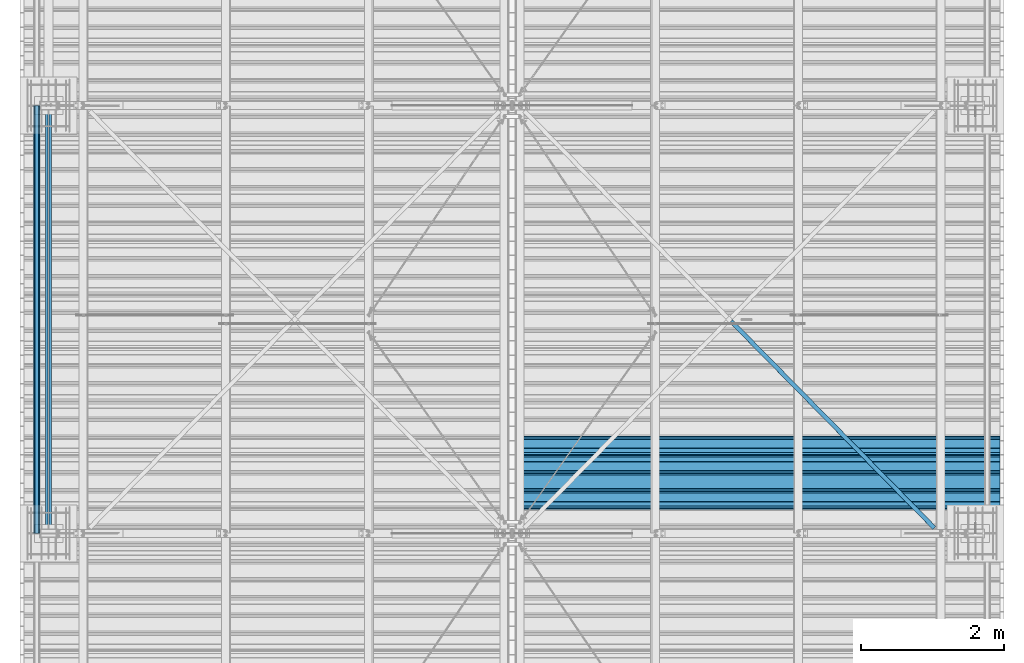
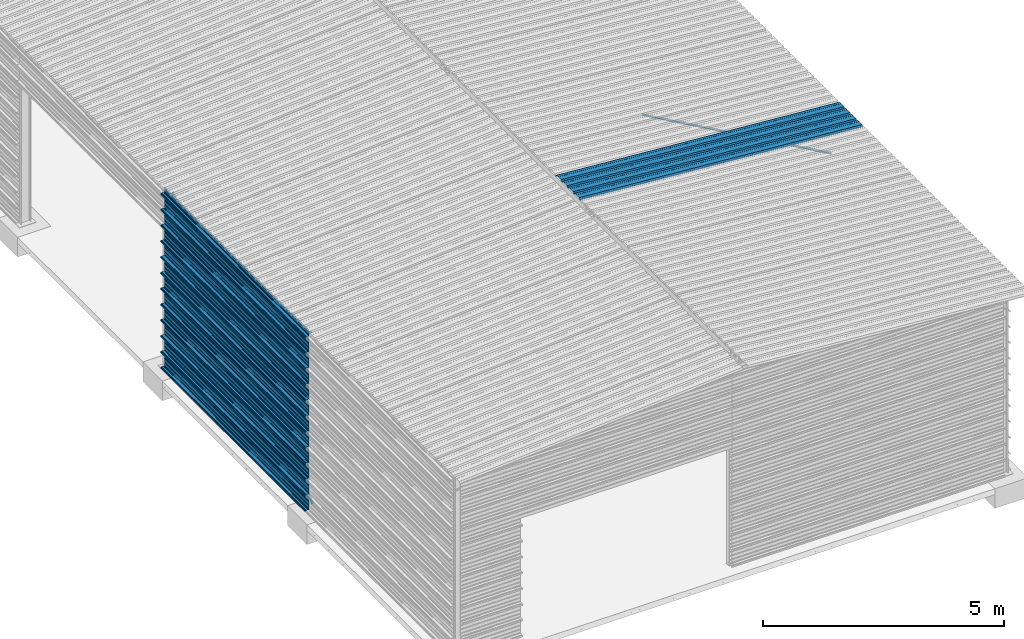
# One storey, part 10 of 70: 14 beams, 2 members, 16 elements without a shape of their own.
"""IFC2X3 building model written with IfcOpenShell, lengths in millimetres."""

import ifcopenshell
import ifcopenshell.guid

model = None  # the IFC model being written
_history = None  # IfcOwnerHistory: only IFC2X3 demands one
_inside = {}  # id of a spatial element -> (the spatial element, [elements in it])
_under = {}  # id of a project, library or spatial element -> (it, [spatial elements below it])
_declared = {}  # id of a project -> (the project, [libraries it declares])
_typed = {}  # id of a type object -> (the type object, [elements of that type])
_made_of = {}  # id of a material, layer set ... -> (it, [elements and type objects made of it])


def new_model(schema):
    """Start an empty IFC model of exactly this schema.

    Asked for "IFC4X3", IfcOpenShell would pick the latest addendum, in which some entities
    have other attributes; the version numbers below select the first issue.
    IFC2X3 requires an IfcOwnerHistory on every rooted entity: one is made here for all.
    """
    global model, _history
    if schema == "IFC4X3":
        model = ifcopenshell.file(schema_version=(4, 3, 0, 0))
    else:
        model = ifcopenshell.file(schema=schema)
    _inside.clear()
    _under.clear()
    _declared.clear()
    _typed.clear()
    _made_of.clear()
    _history = None
    if model.schema == "IFC2X3":
        org = make("IfcOrganization", Name="unknown")
        user = make(
            "IfcPersonAndOrganization",
            ThePerson=make("IfcPerson", FamilyName="unknown"),
            TheOrganization=org,
        )
        app = make(
            "IfcApplication",
            ApplicationDeveloper=org,
            Version="unknown",
            ApplicationFullName="unknown",
            ApplicationIdentifier="unknown",
        )
        _history = make(
            "IfcOwnerHistory",
            OwningUser=user,
            OwningApplication=app,
            ChangeAction="ADDED",
            CreationDate=0,
        )
    return model


def make(cls, **values):
    """One entity of the class cls with the attributes given. An attribute that is None is left unset."""
    return model.create_entity(
        cls, **{name: value for name, value in values.items() if value is not None}
    )


def rooted(cls, **values):
    """An entity with a GlobalId (a new one), such as an element, a storey or a relation."""
    return make(cls, GlobalId=ifcopenshell.guid.new(), OwnerHistory=_history, **values)


def si_unit(unit_type, name, prefix=None):
    """IfcSIUnit, for example si_unit("LENGTHUNIT", "METRE", prefix="MILLI")."""
    return make("IfcSIUnit", UnitType=unit_type, Prefix=prefix, Name=name)


def assignment(units):
    """IfcUnitAssignment: the units of a project."""
    return None if units is None else make("IfcUnitAssignment", Units=units)


def point(xyz):
    """IfcCartesianPoint."""
    return None if xyz is None else make("IfcCartesianPoint", Coordinates=xyz)


def direction(xyz):
    """IfcDirection."""
    return None if xyz is None else make("IfcDirection", DirectionRatios=xyz)


def frame(location, z_axis=None, x_axis=None):
    """IfcAxis2Placement3D, a coordinate frame: its origin and axes. An axis left out is left unset."""
    return make(
        "IfcAxis2Placement3D",
        Location=point(location),
        Axis=direction(z_axis),
        RefDirection=direction(x_axis),
    )


def frame_2d(location, x_axis=None):
    """IfcAxis2Placement2D, a coordinate frame in the plane: its origin and x axis."""
    return make(
        "IfcAxis2Placement2D", Location=point(location), RefDirection=direction(x_axis)
    )


def origin_with_axes():
    """The frame at (0, 0, 0) with the z axis (0, 0, 1) and the x axis (1, 0, 0) written out."""
    return frame((0.0, 0.0, 0.0), z_axis=(0.0, 0.0, 1.0), x_axis=(1.0, 0.0, 0.0))


def origin_2d_with_axis():
    """The frame at (0, 0) in the plane with the x axis (1, 0) written out."""
    return frame_2d((0.0, 0.0), x_axis=(1.0, 0.0))


def place(relative_to, where):
    """IfcLocalPlacement: puts the frame where relative to a parent placement (None: the world)."""
    return make(
        "IfcLocalPlacement", PlacementRelTo=relative_to, RelativePlacement=where
    )


def context(
    kind, dimensions, precision=None, world=None, true_north=None, identifier=None
):
    """IfcGeometricRepresentationContext, for example the 3D "Model" context."""
    return make(
        "IfcGeometricRepresentationContext",
        ContextIdentifier=identifier,
        ContextType=kind,
        CoordinateSpaceDimension=dimensions,
        Precision=precision,
        WorldCoordinateSystem=world,
        TrueNorth=true_north,
    )


def subcontext(parent, identifier, kind, view, scale=None):
    """IfcGeometricRepresentationSubContext, for example "Body" below "Model"."""
    return make(
        "IfcGeometricRepresentationSubContext",
        ContextIdentifier=identifier,
        ContextType=kind,
        ParentContext=parent,
        TargetScale=scale,
        TargetView=view,
    )


def project(units=None, contexts=None):
    """IfcProject with its units and contexts."""
    return rooted(
        "IfcProject",
        Name="project",
        RepresentationContexts=contexts,
        UnitsInContext=assignment(units),
    )


def spatial(cls, under=None, at=None, **own):
    """A site, building, storey or space (cls), placed at a placement, below another one or the project."""
    s = rooted(cls, ObjectPlacement=at, **own)
    if under is not None:
        _under.setdefault(under.id(), (under, []))[1].append(s)
    return s


def polyline(points):
    """IfcPolyline through the points."""
    return make("IfcPolyline", Points=[point(p) for p in points])


def profile(cls, at=None, kind="AREA", **sizes):
    """A parametric profile (cls). Its sizes go by their IFC names, for example OverallWidth=200.0."""
    return make(cls, ProfileType=kind, Position=at, **sizes)


def l_section(**sizes):
    """IfcLShapeProfileDef."""
    return profile("IfcLShapeProfileDef", **sizes)


def outline(outer, holes=None, kind="AREA"):
    """IfcArbitraryClosedProfileDef: a profile drawn as a closed curve; with holes, ...WithVoids."""
    if holes is None:
        return make("IfcArbitraryClosedProfileDef", ProfileType=kind, OuterCurve=outer)
    return make(
        "IfcArbitraryProfileDefWithVoids",
        ProfileType=kind,
        OuterCurve=outer,
        InnerCurves=holes,
    )


def extrude(swept, where, along, depth):
    """IfcExtrudedAreaSolid: the profile swept, set in the frame where, extruded along a direction by depth."""
    return make(
        "IfcExtrudedAreaSolid",
        SweptArea=swept,
        Position=where,
        ExtrudedDirection=direction(along),
        Depth=depth,
    )


def clip(a, b, op="DIFFERENCE"):
    """IfcBooleanClippingResult: the solid a cut by the half space b."""
    return make(
        "IfcBooleanClippingResult", Operator=op, FirstOperand=a, SecondOperand=b
    )


def halfspace(plane, agree):
    """IfcHalfSpaceSolid: all space on one side of the plane z = 0 of the frame plane."""
    return make(
        "IfcHalfSpaceSolid",
        BaseSurface=make("IfcPlane", Position=plane),
        AgreementFlag=agree,
    )


def shape(context_of_items, identifier, shape_type, items):
    """IfcShapeRepresentation: the items that make up one representation, for example the "Body"."""
    return make(
        "IfcShapeRepresentation",
        ContextOfItems=context_of_items,
        RepresentationIdentifier=identifier,
        RepresentationType=shape_type,
        Items=items,
    )


def material(Name=None, Category=None):
    """IfcMaterial."""
    return make("IfcMaterial", Name=Name, Category=Category)


def made_of(thing, what):
    """Note that an element or type object is made of a material, layer set ...; save() writes the relation."""
    if what is not None:
        _made_of.setdefault(what.id(), (what, []))[1].append(thing)
    return thing


def type_object(cls, material=None, **own):
    """A type object (cls), such as IfcWallType, which elements share."""
    return made_of(rooted(cls, **own), material)


def element(
    cls,
    number,
    at=None,
    inside=None,
    cuts=None,
    type_object=None,
    material=None,
    context=None,
    identifier="Body",
    shape_type=None,
    held_by="IfcProductDefinitionShape",
    body=None,
    shapes=None,
    **own,
):
    """One element of the class cls, such as IfcWall. Its Tag is "e" and its number.

    at: its placement. inside: the storey or other place that contains it. cuts: it is an
    opening in that element (IfcRelVoidsElement). A single representation is given by context,
    identifier, shape_type and body (its items); several are given by shapes. held_by: the class
    of the entity that holds the representations. save() writes the other relations.
    """
    e = rooted(cls, Tag="e%d" % number, ObjectPlacement=at, **own)
    if body is not None:
        shapes = [shape(context, identifier, shape_type, body)]
    if shapes is not None:
        e.Representation = make(held_by, Representations=shapes)
    if inside is not None:
        _inside.setdefault(inside.id(), (inside, []))[1].append(e)
    if cuts is not None:
        rooted(
            "IfcRelVoidsElement", RelatingBuildingElement=cuts, RelatedOpeningElement=e
        )
    if type_object is not None:
        _typed.setdefault(type_object.id(), (type_object, []))[1].append(e)
    return made_of(e, material)


def aggregate(whole, parts):
    """IfcRelAggregates: a whole, such as a stair, and the parts it consists of."""
    return rooted("IfcRelAggregates", RelatingObject=whole, RelatedObjects=parts)


def save(model, path):
    """Write the relations noted so far, then the file.

    IfcRelAggregates (storeys below a building ...), IfcRelContainedInSpatialStructure (elements
    in a storey), IfcRelDefinesByType, IfcRelAssociatesMaterial and IfcRelDeclares: one each for
    every whole, place, type object, material and project.
    """
    for whole, parts in _under.values():
        aggregate(whole, parts)
    for where, things in _inside.values():
        rooted(
            "IfcRelContainedInSpatialStructure",
            RelatedElements=things,
            RelatingStructure=where,
        )
    for kind, things in _typed.values():
        rooted("IfcRelDefinesByType", RelatedObjects=things, RelatingType=kind)
    for what, things in _made_of.values():
        rooted("IfcRelAssociatesMaterial", RelatedObjects=things, RelatingMaterial=what)
    for by, libraries in _declared.values():
        rooted("IfcRelDeclares", RelatingContext=by, RelatedDefinitions=libraries)
    model.write(path)


model = new_model("IFC2X3")

# Units and contexts
model_context = context("Model", 3, precision=1e-05, world=origin_with_axes())
body_context = subcontext(model_context, "Body", "Model", "MODEL_VIEW")
ifc_project = project(units=[si_unit("LENGTHUNIT", "METRE", prefix="MILLI"), si_unit("AREAUNIT", "SQUARE_METRE"), si_unit("VOLUMEUNIT", "CUBIC_METRE"), si_unit("MASSUNIT", "GRAM", prefix="KILO"), si_unit("TIMEUNIT", "SECOND"), si_unit("PLANEANGLEUNIT", "RADIAN"), si_unit("SOLIDANGLEUNIT", "STERADIAN"), si_unit("THERMODYNAMICTEMPERATUREUNIT", "DEGREE_CELSIUS"), si_unit("LUMINOUSINTENSITYUNIT", "LUMEN")], contexts=[model_context])

# Site, building, storey
site_placement = place(None, origin_with_axes())
site = spatial("IfcSite", under=ifc_project, at=site_placement, CompositionType="ELEMENT")
building_placement = place(site_placement, origin_with_axes())
building = spatial("IfcBuilding", under=site, at=building_placement, Name="Undefined", CompositionType="ELEMENT")
storey_placement = place(building_placement, origin_with_axes())
storey = spatial("IfcBuildingStorey", under=building, at=storey_placement, Name="Undefined", CompositionType="ELEMENT", Elevation=0.0)

# Assembly, member
assembly_1_placement = place(storey_placement, origin_with_axes())
assembly_1 = element("IfcElementAssembly", 1, at=assembly_1_placement, inside=storey, Name="Steel Assembly", AssemblyPlace="NOTDEFINED", PredefinedType="RIGID_FRAME")
ifc_material = material(Name="STEEL/S235JR")
member_type = type_object("IfcMemberType", PredefinedType="NOTDEFINED")
member_1_placement = place(assembly_1_placement, frame((-23.999999998379, 6091.79999354738, 4437.40000481649), z_axis=(0.0, -0.6, -0.8), x_axis=(0.0, 0.8, -0.6)))
member_1 = element("IfcMember", 2, at=member_1_placement, type_object=member_type, material=ifc_material, Name="POUTRE", context=body_context, shape_type="SweptSolid", body=[
    extrude(l_section(Depth=40.0, Width=40.0, Thickness=4.0, FilletRadius=6.0, EdgeRadius=3.0, at=origin_2d_with_axis()), frame((7267.75482272153, 0.0, 0.0), z_axis=(-1.0, 0.0, 0.0), x_axis=(0.0, -1.0, 0.0)), (0.0, 0.0, 1.0), 7267.75),
])
aggregate(assembly_1, [member_1])

assembly_2_placement = place(storey_placement, origin_with_axes())
assembly_2 = element("IfcElementAssembly", 3, at=assembly_2_placement, inside=storey, Name="Steel Assembly", AssemblyPlace="NOTDEFINED", PredefinedType="RIGID_FRAME")
member_2_placement = place(assembly_2_placement, frame((24.0000000026739, 6093.99614827963, 76.7471111867323), z_axis=(1.0, 0.0, 0.0), x_axis=(0.0, 0.8, 0.6)))
member_2 = element("IfcMember", 4, at=member_2_placement, type_object=member_type, material=ifc_material, Name="POUTRE", context=body_context, shape_type="SweptSolid", body=[
    extrude(l_section(Depth=40.0, Width=40.0, Thickness=4.0, FilletRadius=6.0, EdgeRadius=3.0, at=origin_2d_with_axis()), frame((7267.75482272153, 0.0, 0.0), z_axis=(-1.0, 0.0, 0.0), x_axis=(0.0, -1.0, 0.0)), (0.0, 0.0, 1.0), 7267.75),
])
aggregate(assembly_2, [member_2])

# Assembly, beam
assembly_3_placement = place(storey_placement, origin_with_axes())
assembly_3 = element("IfcElementAssembly", 5, at=assembly_3_placement, inside=storey, Name="Steel Assembly", AssemblyPlace="NOTDEFINED", PredefinedType="RIGID_FRAME")
beam_type_1 = type_object("IfcBeamType", Name="4.40", PredefinedType="NOTDEFINED")
beam_1_placement = place(assembly_3_placement, frame((6563.60751131961, 6850.00000000015, 5336.31760454369), z_axis=(-0.0766964990376782, 0.0, -0.997054485489817), x_axis=(0.997054485489817, 0.0, -0.0766964990376783)))
beam_1 = element("IfcBeam", 6, at=beam_1_placement, type_object=beam_type_1, material=ifc_material, ObjectType="4.40", context=body_context, shape_type="SweptSolid", body=[
    extrude(outline(polyline([(509.415161132813, 19.5000000011705), (490.584838867188, 19.5000000011705), (468.084838867188, -20.4999999988113), (406.585784912109, -20.4999999988113), (404.585784912109, -18.4999999988122), (345.414215087891, -18.4999999988122), (343.414215087891, -20.4999999988113), (281.915161132813, -20.4999999988113), (259.415161132813, 19.5000000011705), (240.584854125977, 19.5000000011705), (218.084854125977, -20.4999999988113), (156.585784912109, -20.4999999988113), (154.585784912109, -18.4999999988122), (95.4142150878906, -18.4999999988122), (93.4142150878906, -20.4999999988113), (31.9151515960693, -20.4999999988113), (9.41515254974365, 19.5000000011705), (-9.41515254974365, 19.5000000011705), (-31.9151515960693, -20.4999999988113), (-93.4142150878906, -20.4999999988113), (-95.4142150878906, -18.4999999988122), (-154.585784912109, -18.4999999988122), (-156.585784912109, -20.4999999988113), (-218.084854125977, -20.4999999988113), (-240.584854125977, 19.5000000011705), (-259.415161132813, 19.5000000011705), (-281.915161132813, -20.4999999988113), (-343.414215087891, -20.4999999988113), (-345.414215087891, -18.4999999988122), (-404.585784912109, -18.4999999988122), (-406.585784912109, -20.4999999988113), (-468.084838867188, -20.4999999988113), (-490.584838867188, 19.5000000011705), (-509.415161132813, 19.5000000011705), (-516.482360839844, 6.9361057293263), (-517.353942871094, 7.42636680720625), (-510.0, 20.5000000011705), (-490.0, 20.5000000011705), (-467.5, -19.4999999988122), (-407.0, -19.4999999988122), (-405.0, -17.4999999988131), (-345.0, -17.4999999988131), (-343.0, -19.4999999988122), (-282.5, -19.4999999988122), (-260.0, 20.5000000011705), (-240.0, 20.5000000011705), (-217.5, -19.4999999988122), (-157.0, -19.4999999988122), (-155.0, -17.4999999988131), (-95.0, -17.4999999988131), (-93.0, -19.4999999988122), (-32.5, -19.4999999988122), (-10.0, 20.5000000011705), (10.0, 20.5000000011705), (32.5, -19.4999999988122), (93.0, -19.4999999988122), (95.0, -17.4999999988131), (155.0, -17.4999999988131), (157.0, -19.4999999988122), (217.5, -19.4999999988122), (240.0, 20.5000000011705), (260.0, 20.5000000011705), (282.5, -19.4999999988122), (343.0, -19.4999999988122), (345.0, -17.4999999988131), (405.0, -17.4999999988131), (407.0, -19.4999999988122), (467.5, -19.4999999988122), (490.0, 20.5000000011705), (510.0, 20.5000000011705), (517.353942871094, 7.42636680720625), (516.482360839844, 6.9361057293263), (509.415161132813, 19.5000000011705)])), frame((6799.99999999733, 2.8421709430404e-14, 0.0), z_axis=(-1.0, 0.0, 0.0), x_axis=(0.0, -1.0, 0.0)), (0.0, 0.0, 1.0), 6800.0),
])
aggregate(assembly_3, [beam_1])

assembly_4_placement = place(storey_placement, origin_with_axes())
assembly_4 = element("IfcElementAssembly", 7, at=assembly_4_placement, inside=storey, Name="Steel Assembly", AssemblyPlace="NOTDEFINED", PredefinedType="RIGID_FRAME")
beam_type_2 = type_object("IfcBeamType", Name="400", PredefinedType="NOTDEFINED")
beam_2_placement = place(assembly_4_placement, frame((-165.499999998334, 6000.0, 4618.17396601053), z_axis=(-1.0, 0.0, 0.0), x_axis=(0.0, 1.0, 0.0)))
beam_2 = element("IfcBeam", 8, at=beam_2_placement, type_object=beam_type_2, material=ifc_material, ObjectType="400", context=body_context, shape_type="Clipping", body=[
    clip(extrude(outline(polyline([(218.25, -24.994083404541), (214.25, -31.8999996185303), (214.25, -45.5), (199.75, -45.5), (194.25, -42.5), (188.75, -45.5), (124.25, -45.5), (114.25, -41.5), (104.25, -45.5), (24.25, -45.5), (14.25, -41.5), (4.25, -45.5), (-75.75, -45.5), (-85.75, -41.5), (-95.75, -45.5), (-160.25, -45.5), (-165.75, -42.5), (-171.25, -45.5), (-185.75, -45.5), (-185.75, -30.711540222168), (-181.75, -23.8111782073975), (-181.75, 23.311637878418), (-185.75, 30.2119998931885), (-185.75, 44.5), (-217.25, 44.5), (-217.25, 34.7999992370605), (-218.25, 34.7999992370605), (-218.25, 45.5), (-184.75, 45.5), (-184.75, 30.480884552002), (-180.75, 23.5805225372314), (-180.75, -24.0800628662109), (-184.75, -30.9804248809814), (-184.75, -44.5), (-171.504989624023, -44.5), (-165.75, -41.360912322998), (-159.995010375977, -44.5), (-95.9425811767578, -44.5), (-85.75, -40.422966003418), (-75.5574188232422, -44.5), (4.05741739273071, -44.5), (14.25, -40.422966003418), (24.4425830841064, -44.5), (104.057418823242, -44.5), (114.25, -40.422966003418), (124.442581176758, -44.5), (188.495010375977, -44.5), (194.25, -41.360912322998), (200.004989624023, -44.5), (213.25, -44.5), (213.25, -31.6313018798828), (217.25, -24.7253856658936), (217.25, 21.7253856658936), (213.25, 28.6313018798828), (213.25, 42.0), (187.25, 42.0), (187.25, 32.5499992370605), (186.25, 32.5499992370605), (186.25, 43.0), (214.25, 43.0), (214.25, 28.8999996185303), (218.25, 21.994083404541), (218.25, -24.994083404541)])), frame((6000.0, 0.0, 0.0), z_axis=(-1.0, 0.0, 0.0), x_axis=(0.0, -1.0, 0.0)), (0.0, 0.0, 1.0), 6000.0), halfspace(frame((5.6843418860808e-14, 36.6804312648874, -45.0000000000003), z_axis=(0.0, -1.0, 0.0), x_axis=(0.0, 0.0, 1.0)), False)),
])
aggregate(assembly_4, [beam_2])

assembly_5_placement = place(storey_placement, origin_with_axes())
assembly_5 = element("IfcElementAssembly", 9, at=assembly_5_placement, inside=storey, Name="Steel Assembly", AssemblyPlace="NOTDEFINED", PredefinedType="RIGID_FRAME")
beam_3_placement = place(assembly_5_placement, frame((-165.499999998485, 6000.0, 4218.17396601053), z_axis=(-1.0, 0.0, 0.0), x_axis=(0.0, 1.0, 0.0)))
beam_3 = element("IfcBeam", 10, at=beam_3_placement, type_object=beam_type_2, material=ifc_material, ObjectType="400", context=body_context, shape_type="SweptSolid", body=[
    extrude(outline(polyline([(218.25, -24.994083404541), (214.25, -31.8999996185303), (214.25, -45.5), (199.75, -45.5), (194.25, -42.5), (188.75, -45.5), (124.25, -45.5), (114.25, -41.5), (104.25, -45.5), (24.25, -45.5), (14.25, -41.5), (4.25, -45.5), (-75.75, -45.5), (-85.75, -41.5), (-95.75, -45.5), (-160.25, -45.5), (-165.75, -42.5), (-171.25, -45.5), (-185.75, -45.5), (-185.75, -30.711540222168), (-181.75, -23.8111782073975), (-181.75, 23.311637878418), (-185.75, 30.2119998931885), (-185.75, 44.5), (-217.25, 44.5), (-217.25, 34.7999992370605), (-218.25, 34.7999992370605), (-218.25, 45.5), (-184.75, 45.5), (-184.75, 30.480884552002), (-180.75, 23.5805225372314), (-180.75, -24.0800628662109), (-184.75, -30.9804248809814), (-184.75, -44.5), (-171.504989624023, -44.5), (-165.75, -41.360912322998), (-159.995010375977, -44.5), (-95.9425811767578, -44.5), (-85.75, -40.422966003418), (-75.5574188232422, -44.5), (4.05741739273071, -44.5), (14.25, -40.422966003418), (24.4425830841064, -44.5), (104.057418823242, -44.5), (114.25, -40.422966003418), (124.442581176758, -44.5), (188.495010375977, -44.5), (194.25, -41.360912322998), (200.004989624023, -44.5), (213.25, -44.5), (213.25, -31.6313018798828), (217.25, -24.7253856658936), (217.25, 21.7253856658936), (213.25, 28.6313018798828), (213.25, 42.0), (187.25, 42.0), (187.25, 32.5499992370605), (186.25, 32.5499992370605), (186.25, 43.0), (214.25, 43.0), (214.25, 28.8999996185303), (218.25, 21.994083404541), (218.25, -24.994083404541)])), frame((6000.0, 0.0, 0.0), z_axis=(-1.0, 0.0, 0.0), x_axis=(0.0, -1.0, 0.0)), (0.0, 0.0, 1.0), 6000.0),
])
aggregate(assembly_5, [beam_3])

assembly_6_placement = place(storey_placement, origin_with_axes())
assembly_6 = element("IfcElementAssembly", 11, at=assembly_6_placement, inside=storey, Name="Steel Assembly", AssemblyPlace="NOTDEFINED", PredefinedType="RIGID_FRAME")
beam_4_placement = place(assembly_6_placement, frame((-165.499999998638, 6000.0, 3818.17396601053), z_axis=(-1.0, 0.0, 0.0), x_axis=(0.0, 1.0, 0.0)))
beam_4 = element("IfcBeam", 12, at=beam_4_placement, type_object=beam_type_2, material=ifc_material, ObjectType="400", context=body_context, shape_type="SweptSolid", body=[
    extrude(outline(polyline([(218.25, -24.994083404541), (214.25, -31.8999996185303), (214.25, -45.5), (199.75, -45.5), (194.25, -42.5), (188.75, -45.5), (124.25, -45.5), (114.25, -41.5), (104.25, -45.5), (24.25, -45.5), (14.25, -41.5), (4.25, -45.5), (-75.75, -45.5), (-85.75, -41.5), (-95.75, -45.5), (-160.25, -45.5), (-165.75, -42.5), (-171.25, -45.5), (-185.75, -45.5), (-185.75, -30.711540222168), (-181.75, -23.8111782073975), (-181.75, 23.311637878418), (-185.75, 30.2119998931885), (-185.75, 44.5), (-217.25, 44.5), (-217.25, 34.7999992370605), (-218.25, 34.7999992370605), (-218.25, 45.5), (-184.75, 45.5), (-184.75, 30.480884552002), (-180.75, 23.5805225372314), (-180.75, -24.0800628662109), (-184.75, -30.9804248809814), (-184.75, -44.5), (-171.504989624023, -44.5), (-165.75, -41.360912322998), (-159.995010375977, -44.5), (-95.9425811767578, -44.5), (-85.75, -40.422966003418), (-75.5574188232422, -44.5), (4.05741739273071, -44.5), (14.25, -40.422966003418), (24.4425830841064, -44.5), (104.057418823242, -44.5), (114.25, -40.422966003418), (124.442581176758, -44.5), (188.495010375977, -44.5), (194.25, -41.360912322998), (200.004989624023, -44.5), (213.25, -44.5), (213.25, -31.6313018798828), (217.25, -24.7253856658936), (217.25, 21.7253856658936), (213.25, 28.6313018798828), (213.25, 42.0), (187.25, 42.0), (187.25, 32.5499992370605), (186.25, 32.5499992370605), (186.25, 43.0), (214.25, 43.0), (214.25, 28.8999996185303), (218.25, 21.994083404541), (218.25, -24.994083404541)])), frame((6000.0, 0.0, 0.0), z_axis=(-1.0, 0.0, 0.0), x_axis=(0.0, -1.0, 0.0)), (0.0, 0.0, 1.0), 6000.0),
])
aggregate(assembly_6, [beam_4])

assembly_7_placement = place(storey_placement, origin_with_axes())
assembly_7 = element("IfcElementAssembly", 13, at=assembly_7_placement, inside=storey, Name="Steel Assembly", AssemblyPlace="NOTDEFINED", PredefinedType="RIGID_FRAME")
beam_5_placement = place(assembly_7_placement, frame((-165.499999998789, 6000.0, 3418.17396601053), z_axis=(-1.0, 0.0, 0.0), x_axis=(0.0, 1.0, 0.0)))
beam_5 = element("IfcBeam", 14, at=beam_5_placement, type_object=beam_type_2, material=ifc_material, ObjectType="400", context=body_context, shape_type="SweptSolid", body=[
    extrude(outline(polyline([(218.25, -24.994083404541), (214.25, -31.8999996185303), (214.25, -45.5), (199.75, -45.5), (194.25, -42.5), (188.75, -45.5), (124.25, -45.5), (114.25, -41.5), (104.25, -45.5), (24.25, -45.5), (14.25, -41.5), (4.25, -45.5), (-75.75, -45.5), (-85.75, -41.5), (-95.75, -45.5), (-160.25, -45.5), (-165.75, -42.5), (-171.25, -45.5), (-185.75, -45.5), (-185.75, -30.711540222168), (-181.75, -23.8111782073975), (-181.75, 23.311637878418), (-185.75, 30.2119998931885), (-185.75, 44.5), (-217.25, 44.5), (-217.25, 34.7999992370605), (-218.25, 34.7999992370605), (-218.25, 45.5), (-184.75, 45.5), (-184.75, 30.480884552002), (-180.75, 23.5805225372314), (-180.75, -24.0800628662109), (-184.75, -30.9804248809814), (-184.75, -44.5), (-171.504989624023, -44.5), (-165.75, -41.360912322998), (-159.995010375977, -44.5), (-95.9425811767578, -44.5), (-85.75, -40.422966003418), (-75.5574188232422, -44.5), (4.05741739273071, -44.5), (14.25, -40.422966003418), (24.4425830841064, -44.5), (104.057418823242, -44.5), (114.25, -40.422966003418), (124.442581176758, -44.5), (188.495010375977, -44.5), (194.25, -41.360912322998), (200.004989624023, -44.5), (213.25, -44.5), (213.25, -31.6313018798828), (217.25, -24.7253856658936), (217.25, 21.7253856658936), (213.25, 28.6313018798828), (213.25, 42.0), (187.25, 42.0), (187.25, 32.5499992370605), (186.25, 32.5499992370605), (186.25, 43.0), (214.25, 43.0), (214.25, 28.8999996185303), (218.25, 21.994083404541), (218.25, -24.994083404541)])), frame((6000.0, 0.0, 0.0), z_axis=(-1.0, 0.0, 0.0), x_axis=(0.0, -1.0, 0.0)), (0.0, 0.0, 1.0), 6000.0),
])
aggregate(assembly_7, [beam_5])

assembly_8_placement = place(storey_placement, origin_with_axes())
assembly_8 = element("IfcElementAssembly", 15, at=assembly_8_placement, inside=storey, Name="Steel Assembly", AssemblyPlace="NOTDEFINED", PredefinedType="RIGID_FRAME")
beam_6_placement = place(assembly_8_placement, frame((-165.49999999894, 6000.0, 3018.17396601053), z_axis=(-1.0, 0.0, 0.0), x_axis=(0.0, 1.0, 0.0)))
beam_6 = element("IfcBeam", 16, at=beam_6_placement, type_object=beam_type_2, material=ifc_material, ObjectType="400", context=body_context, shape_type="SweptSolid", body=[
    extrude(outline(polyline([(218.25, -24.994083404541), (214.25, -31.8999996185303), (214.25, -45.5), (199.75, -45.5), (194.25, -42.5), (188.75, -45.5), (124.25, -45.5), (114.25, -41.5), (104.25, -45.5), (24.25, -45.5), (14.25, -41.5), (4.25, -45.5), (-75.75, -45.5), (-85.75, -41.5), (-95.75, -45.5), (-160.25, -45.5), (-165.75, -42.5), (-171.25, -45.5), (-185.75, -45.5), (-185.75, -30.711540222168), (-181.75, -23.8111782073975), (-181.75, 23.311637878418), (-185.75, 30.2119998931885), (-185.75, 44.5), (-217.25, 44.5), (-217.25, 34.7999992370605), (-218.25, 34.7999992370605), (-218.25, 45.5), (-184.75, 45.5), (-184.75, 30.480884552002), (-180.75, 23.5805225372314), (-180.75, -24.0800628662109), (-184.75, -30.9804248809814), (-184.75, -44.5), (-171.504989624023, -44.5), (-165.75, -41.360912322998), (-159.995010375977, -44.5), (-95.9425811767578, -44.5), (-85.75, -40.422966003418), (-75.5574188232422, -44.5), (4.05741739273071, -44.5), (14.25, -40.422966003418), (24.4425830841064, -44.5), (104.057418823242, -44.5), (114.25, -40.422966003418), (124.442581176758, -44.5), (188.495010375977, -44.5), (194.25, -41.360912322998), (200.004989624023, -44.5), (213.25, -44.5), (213.25, -31.6313018798828), (217.25, -24.7253856658936), (217.25, 21.7253856658936), (213.25, 28.6313018798828), (213.25, 42.0), (187.25, 42.0), (187.25, 32.5499992370605), (186.25, 32.5499992370605), (186.25, 43.0), (214.25, 43.0), (214.25, 28.8999996185303), (218.25, 21.994083404541), (218.25, -24.994083404541)])), frame((6000.0, 0.0, 0.0), z_axis=(-1.0, 0.0, 0.0), x_axis=(0.0, -1.0, 0.0)), (0.0, 0.0, 1.0), 6000.0),
])
aggregate(assembly_8, [beam_6])

assembly_9_placement = place(storey_placement, origin_with_axes())
assembly_9 = element("IfcElementAssembly", 17, at=assembly_9_placement, inside=storey, Name="Steel Assembly", AssemblyPlace="NOTDEFINED", PredefinedType="RIGID_FRAME")
beam_7_placement = place(assembly_9_placement, frame((-165.499999999092, 6000.0, 2618.17396601053), z_axis=(-1.0, 0.0, 0.0), x_axis=(0.0, 1.0, 0.0)))
beam_7 = element("IfcBeam", 18, at=beam_7_placement, type_object=beam_type_2, material=ifc_material, ObjectType="400", context=body_context, shape_type="SweptSolid", body=[
    extrude(outline(polyline([(218.25, -24.994083404541), (214.25, -31.8999996185303), (214.25, -45.5), (199.75, -45.5), (194.25, -42.5), (188.75, -45.5), (124.25, -45.5), (114.25, -41.5), (104.25, -45.5), (24.25, -45.5), (14.25, -41.5), (4.25, -45.5), (-75.75, -45.5), (-85.75, -41.5), (-95.75, -45.5), (-160.25, -45.5), (-165.75, -42.5), (-171.25, -45.5), (-185.75, -45.5), (-185.75, -30.711540222168), (-181.75, -23.8111782073975), (-181.75, 23.311637878418), (-185.75, 30.2119998931885), (-185.75, 44.5), (-217.25, 44.5), (-217.25, 34.7999992370605), (-218.25, 34.7999992370605), (-218.25, 45.5), (-184.75, 45.5), (-184.75, 30.480884552002), (-180.75, 23.5805225372314), (-180.75, -24.0800628662109), (-184.75, -30.9804248809814), (-184.75, -44.5), (-171.504989624023, -44.5), (-165.75, -41.360912322998), (-159.995010375977, -44.5), (-95.9425811767578, -44.5), (-85.75, -40.422966003418), (-75.5574188232422, -44.5), (4.05741739273071, -44.5), (14.25, -40.422966003418), (24.4425830841064, -44.5), (104.057418823242, -44.5), (114.25, -40.422966003418), (124.442581176758, -44.5), (188.495010375977, -44.5), (194.25, -41.360912322998), (200.004989624023, -44.5), (213.25, -44.5), (213.25, -31.6313018798828), (217.25, -24.7253856658936), (217.25, 21.7253856658936), (213.25, 28.6313018798828), (213.25, 42.0), (187.25, 42.0), (187.25, 32.5499992370605), (186.25, 32.5499992370605), (186.25, 43.0), (214.25, 43.0), (214.25, 28.8999996185303), (218.25, 21.994083404541), (218.25, -24.994083404541)])), frame((6000.0, 0.0, 0.0), z_axis=(-1.0, 0.0, 0.0), x_axis=(0.0, -1.0, 0.0)), (0.0, 0.0, 1.0), 6000.0),
])
aggregate(assembly_9, [beam_7])

assembly_10_placement = place(storey_placement, origin_with_axes())
assembly_10 = element("IfcElementAssembly", 19, at=assembly_10_placement, inside=storey, Name="Steel Assembly", AssemblyPlace="NOTDEFINED", PredefinedType="RIGID_FRAME")
beam_8_placement = place(assembly_10_placement, frame((-165.499999999243, 6000.0, 2218.17396601053), z_axis=(-1.0, 0.0, 0.0), x_axis=(0.0, 1.0, 0.0)))
beam_8 = element("IfcBeam", 20, at=beam_8_placement, type_object=beam_type_2, material=ifc_material, ObjectType="400", context=body_context, shape_type="SweptSolid", body=[
    extrude(outline(polyline([(218.25, -24.994083404541), (214.25, -31.8999996185303), (214.25, -45.5), (199.75, -45.5), (194.25, -42.5), (188.75, -45.5), (124.25, -45.5), (114.25, -41.5), (104.25, -45.5), (24.25, -45.5), (14.25, -41.5), (4.25, -45.5), (-75.75, -45.5), (-85.75, -41.5), (-95.75, -45.5), (-160.25, -45.5), (-165.75, -42.5), (-171.25, -45.5), (-185.75, -45.5), (-185.75, -30.711540222168), (-181.75, -23.8111782073975), (-181.75, 23.311637878418), (-185.75, 30.2119998931885), (-185.75, 44.5), (-217.25, 44.5), (-217.25, 34.7999992370605), (-218.25, 34.7999992370605), (-218.25, 45.5), (-184.75, 45.5), (-184.75, 30.480884552002), (-180.75, 23.5805225372314), (-180.75, -24.0800628662109), (-184.75, -30.9804248809814), (-184.75, -44.5), (-171.504989624023, -44.5), (-165.75, -41.360912322998), (-159.995010375977, -44.5), (-95.9425811767578, -44.5), (-85.75, -40.422966003418), (-75.5574188232422, -44.5), (4.05741739273071, -44.5), (14.25, -40.422966003418), (24.4425830841064, -44.5), (104.057418823242, -44.5), (114.25, -40.422966003418), (124.442581176758, -44.5), (188.495010375977, -44.5), (194.25, -41.360912322998), (200.004989624023, -44.5), (213.25, -44.5), (213.25, -31.6313018798828), (217.25, -24.7253856658936), (217.25, 21.7253856658936), (213.25, 28.6313018798828), (213.25, 42.0), (187.25, 42.0), (187.25, 32.5499992370605), (186.25, 32.5499992370605), (186.25, 43.0), (214.25, 43.0), (214.25, 28.8999996185303), (218.25, 21.994083404541), (218.25, -24.994083404541)])), frame((6000.0, 0.0, 0.0), z_axis=(-1.0, 0.0, 0.0), x_axis=(0.0, -1.0, 0.0)), (0.0, 0.0, 1.0), 6000.0),
])
aggregate(assembly_10, [beam_8])

assembly_11_placement = place(storey_placement, origin_with_axes())
assembly_11 = element("IfcElementAssembly", 21, at=assembly_11_placement, inside=storey, Name="Steel Assembly", AssemblyPlace="NOTDEFINED", PredefinedType="RIGID_FRAME")
beam_9_placement = place(assembly_11_placement, frame((-165.499999999396, 6000.0, 1818.17396601053), z_axis=(-1.0, 0.0, 0.0), x_axis=(0.0, 1.0, 0.0)))
beam_9 = element("IfcBeam", 22, at=beam_9_placement, type_object=beam_type_2, material=ifc_material, ObjectType="400", context=body_context, shape_type="SweptSolid", body=[
    extrude(outline(polyline([(218.25, -24.994083404541), (214.25, -31.8999996185303), (214.25, -45.5), (199.75, -45.5), (194.25, -42.5), (188.75, -45.5), (124.25, -45.5), (114.25, -41.5), (104.25, -45.5), (24.25, -45.5), (14.25, -41.5), (4.25, -45.5), (-75.75, -45.5), (-85.75, -41.5), (-95.75, -45.5), (-160.25, -45.5), (-165.75, -42.5), (-171.25, -45.5), (-185.75, -45.5), (-185.75, -30.711540222168), (-181.75, -23.8111782073975), (-181.75, 23.311637878418), (-185.75, 30.2119998931885), (-185.75, 44.5), (-217.25, 44.5), (-217.25, 34.7999992370605), (-218.25, 34.7999992370605), (-218.25, 45.5), (-184.75, 45.5), (-184.75, 30.480884552002), (-180.75, 23.5805225372314), (-180.75, -24.0800628662109), (-184.75, -30.9804248809814), (-184.75, -44.5), (-171.504989624023, -44.5), (-165.75, -41.360912322998), (-159.995010375977, -44.5), (-95.9425811767578, -44.5), (-85.75, -40.422966003418), (-75.5574188232422, -44.5), (4.05741739273071, -44.5), (14.25, -40.422966003418), (24.4425830841064, -44.5), (104.057418823242, -44.5), (114.25, -40.422966003418), (124.442581176758, -44.5), (188.495010375977, -44.5), (194.25, -41.360912322998), (200.004989624023, -44.5), (213.25, -44.5), (213.25, -31.6313018798828), (217.25, -24.7253856658936), (217.25, 21.7253856658936), (213.25, 28.6313018798828), (213.25, 42.0), (187.25, 42.0), (187.25, 32.5499992370605), (186.25, 32.5499992370605), (186.25, 43.0), (214.25, 43.0), (214.25, 28.8999996185303), (218.25, 21.994083404541), (218.25, -24.994083404541)])), frame((6000.0, 0.0, 0.0), z_axis=(-1.0, 0.0, 0.0), x_axis=(0.0, -1.0, 0.0)), (0.0, 0.0, 1.0), 6000.0),
])
aggregate(assembly_11, [beam_9])

assembly_12_placement = place(storey_placement, origin_with_axes())
assembly_12 = element("IfcElementAssembly", 23, at=assembly_12_placement, inside=storey, Name="Steel Assembly", AssemblyPlace="NOTDEFINED", PredefinedType="RIGID_FRAME")
beam_10_placement = place(assembly_12_placement, frame((-165.499999999547, 6000.0, 1418.17396601053), z_axis=(-1.0, 0.0, 0.0), x_axis=(0.0, 1.0, 0.0)))
beam_10 = element("IfcBeam", 24, at=beam_10_placement, type_object=beam_type_2, material=ifc_material, ObjectType="400", context=body_context, shape_type="SweptSolid", body=[
    extrude(outline(polyline([(218.25, -24.994083404541), (214.25, -31.8999996185303), (214.25, -45.5), (199.75, -45.5), (194.25, -42.5), (188.75, -45.5), (124.25, -45.5), (114.25, -41.5), (104.25, -45.5), (24.25, -45.5), (14.25, -41.5), (4.25, -45.5), (-75.75, -45.5), (-85.75, -41.5), (-95.75, -45.5), (-160.25, -45.5), (-165.75, -42.5), (-171.25, -45.5), (-185.75, -45.5), (-185.75, -30.711540222168), (-181.75, -23.8111782073975), (-181.75, 23.311637878418), (-185.75, 30.2119998931885), (-185.75, 44.5), (-217.25, 44.5), (-217.25, 34.7999992370605), (-218.25, 34.7999992370605), (-218.25, 45.5), (-184.75, 45.5), (-184.75, 30.480884552002), (-180.75, 23.5805225372314), (-180.75, -24.0800628662109), (-184.75, -30.9804248809814), (-184.75, -44.5), (-171.504989624023, -44.5), (-165.75, -41.360912322998), (-159.995010375977, -44.5), (-95.9425811767578, -44.5), (-85.75, -40.422966003418), (-75.5574188232422, -44.5), (4.05741739273071, -44.5), (14.25, -40.422966003418), (24.4425830841064, -44.5), (104.057418823242, -44.5), (114.25, -40.422966003418), (124.442581176758, -44.5), (188.495010375977, -44.5), (194.25, -41.360912322998), (200.004989624023, -44.5), (213.25, -44.5), (213.25, -31.6313018798828), (217.25, -24.7253856658936), (217.25, 21.7253856658936), (213.25, 28.6313018798828), (213.25, 42.0), (187.25, 42.0), (187.25, 32.5499992370605), (186.25, 32.5499992370605), (186.25, 43.0), (214.25, 43.0), (214.25, 28.8999996185303), (218.25, 21.994083404541), (218.25, -24.994083404541)])), frame((6000.0, 0.0, 0.0), z_axis=(-1.0, 0.0, 0.0), x_axis=(0.0, -1.0, 0.0)), (0.0, 0.0, 1.0), 6000.0),
])
aggregate(assembly_12, [beam_10])

assembly_13_placement = place(storey_placement, origin_with_axes())
assembly_13 = element("IfcElementAssembly", 25, at=assembly_13_placement, inside=storey, Name="Steel Assembly", AssemblyPlace="NOTDEFINED", PredefinedType="RIGID_FRAME")
beam_11_placement = place(assembly_13_placement, frame((-165.499999999698, 6000.0, 1018.17396601053), z_axis=(-1.0, 0.0, 0.0), x_axis=(0.0, 1.0, 0.0)))
beam_11 = element("IfcBeam", 26, at=beam_11_placement, type_object=beam_type_2, material=ifc_material, ObjectType="400", context=body_context, shape_type="SweptSolid", body=[
    extrude(outline(polyline([(218.25, -24.994083404541), (214.25, -31.8999996185303), (214.25, -45.5), (199.75, -45.5), (194.25, -42.5), (188.75, -45.5), (124.25, -45.5), (114.25, -41.5), (104.25, -45.5), (24.25, -45.5), (14.25, -41.5), (4.25, -45.5), (-75.75, -45.5), (-85.75, -41.5), (-95.75, -45.5), (-160.25, -45.5), (-165.75, -42.5), (-171.25, -45.5), (-185.75, -45.5), (-185.75, -30.711540222168), (-181.75, -23.8111782073975), (-181.75, 23.311637878418), (-185.75, 30.2119998931885), (-185.75, 44.5), (-217.25, 44.5), (-217.25, 34.7999992370605), (-218.25, 34.7999992370605), (-218.25, 45.5), (-184.75, 45.5), (-184.75, 30.480884552002), (-180.75, 23.5805225372314), (-180.75, -24.0800628662109), (-184.75, -30.9804248809814), (-184.75, -44.5), (-171.504989624023, -44.5), (-165.75, -41.360912322998), (-159.995010375977, -44.5), (-95.9425811767578, -44.5), (-85.75, -40.422966003418), (-75.5574188232422, -44.5), (4.05741739273071, -44.5), (14.25, -40.422966003418), (24.4425830841064, -44.5), (104.057418823242, -44.5), (114.25, -40.422966003418), (124.442581176758, -44.5), (188.495010375977, -44.5), (194.25, -41.360912322998), (200.004989624023, -44.5), (213.25, -44.5), (213.25, -31.6313018798828), (217.25, -24.7253856658936), (217.25, 21.7253856658936), (213.25, 28.6313018798828), (213.25, 42.0), (187.25, 42.0), (187.25, 32.5499992370605), (186.25, 32.5499992370605), (186.25, 43.0), (214.25, 43.0), (214.25, 28.8999996185303), (218.25, 21.994083404541), (218.25, -24.994083404541)])), frame((6000.0, 0.0, 0.0), z_axis=(-1.0, 0.0, 0.0), x_axis=(0.0, -1.0, 0.0)), (0.0, 0.0, 1.0), 6000.0),
])
aggregate(assembly_13, [beam_11])

assembly_14_placement = place(storey_placement, origin_with_axes())
assembly_14 = element("IfcElementAssembly", 27, at=assembly_14_placement, inside=storey, Name="Steel Assembly", AssemblyPlace="NOTDEFINED", PredefinedType="RIGID_FRAME")
beam_12_placement = place(assembly_14_placement, frame((-165.499999999851, 6000.0, 618.173966010527), z_axis=(-1.0, 0.0, 0.0), x_axis=(0.0, 1.0, 0.0)))
beam_12 = element("IfcBeam", 28, at=beam_12_placement, type_object=beam_type_2, material=ifc_material, ObjectType="400", context=body_context, shape_type="SweptSolid", body=[
    extrude(outline(polyline([(218.25, -24.994083404541), (214.25, -31.8999996185303), (214.25, -45.5), (199.75, -45.5), (194.25, -42.5), (188.75, -45.5), (124.25, -45.5), (114.25, -41.5), (104.25, -45.5), (24.25, -45.5), (14.25, -41.5), (4.25, -45.5), (-75.75, -45.5), (-85.75, -41.5), (-95.75, -45.5), (-160.25, -45.5), (-165.75, -42.5), (-171.25, -45.5), (-185.75, -45.5), (-185.75, -30.711540222168), (-181.75, -23.8111782073975), (-181.75, 23.311637878418), (-185.75, 30.2119998931885), (-185.75, 44.5), (-217.25, 44.5), (-217.25, 34.7999992370605), (-218.25, 34.7999992370605), (-218.25, 45.5), (-184.75, 45.5), (-184.75, 30.480884552002), (-180.75, 23.5805225372314), (-180.75, -24.0800628662109), (-184.75, -30.9804248809814), (-184.75, -44.5), (-171.504989624023, -44.5), (-165.75, -41.360912322998), (-159.995010375977, -44.5), (-95.9425811767578, -44.5), (-85.75, -40.422966003418), (-75.5574188232422, -44.5), (4.05741739273071, -44.5), (14.25, -40.422966003418), (24.4425830841064, -44.5), (104.057418823242, -44.5), (114.25, -40.422966003418), (124.442581176758, -44.5), (188.495010375977, -44.5), (194.25, -41.360912322998), (200.004989624023, -44.5), (213.25, -44.5), (213.25, -31.6313018798828), (217.25, -24.7253856658936), (217.25, 21.7253856658936), (213.25, 28.6313018798828), (213.25, 42.0), (187.25, 42.0), (187.25, 32.5499992370605), (186.25, 32.5499992370605), (186.25, 43.0), (214.25, 43.0), (214.25, 28.8999996185303), (218.25, 21.994083404541), (218.25, -24.994083404541)])), frame((6000.0, 0.0, 0.0), z_axis=(-1.0, 0.0, 0.0), x_axis=(0.0, -1.0, 0.0)), (0.0, 0.0, 1.0), 6000.0),
])
aggregate(assembly_14, [beam_12])

assembly_15_placement = place(storey_placement, origin_with_axes())
assembly_15 = element("IfcElementAssembly", 29, at=assembly_15_placement, inside=storey, Name="Steel Assembly", AssemblyPlace="NOTDEFINED", PredefinedType="RIGID_FRAME")
beam_13_placement = place(assembly_15_placement, frame((-165.500000000002, 6000.0, 218.173966010527), z_axis=(-1.0, 0.0, 0.0), x_axis=(0.0, 1.0, 0.0)))
beam_13 = element("IfcBeam", 30, at=beam_13_placement, type_object=beam_type_2, material=ifc_material, ObjectType="400", context=body_context, shape_type="SweptSolid", body=[
    extrude(outline(polyline([(218.25, -24.994083404541), (214.25, -31.8999996185303), (214.25, -45.5), (199.75, -45.5), (194.25, -42.5), (188.75, -45.5), (124.25, -45.5), (114.25, -41.5), (104.25, -45.5), (24.25, -45.5), (14.25, -41.5), (4.25, -45.5), (-75.75, -45.5), (-85.75, -41.5), (-95.75, -45.5), (-160.25, -45.5), (-165.75, -42.5), (-171.25, -45.5), (-185.75, -45.5), (-185.75, -30.711540222168), (-181.75, -23.8111782073975), (-181.75, 23.311637878418), (-185.75, 30.2119998931885), (-185.75, 44.5), (-217.25, 44.5), (-217.25, 34.7999992370605), (-218.25, 34.7999992370605), (-218.25, 45.5), (-184.75, 45.5), (-184.75, 30.480884552002), (-180.75, 23.5805225372314), (-180.75, -24.0800628662109), (-184.75, -30.9804248809814), (-184.75, -44.5), (-171.504989624023, -44.5), (-165.75, -41.360912322998), (-159.995010375977, -44.5), (-95.9425811767578, -44.5), (-85.75, -40.422966003418), (-75.5574188232422, -44.5), (4.05741739273071, -44.5), (14.25, -40.422966003418), (24.4425830841064, -44.5), (104.057418823242, -44.5), (114.25, -40.422966003418), (124.442581176758, -44.5), (188.495010375977, -44.5), (194.25, -41.360912322998), (200.004989624023, -44.5), (213.25, -44.5), (213.25, -31.6313018798828), (217.25, -24.7253856658936), (217.25, 21.7253856658936), (213.25, 28.6313018798828), (213.25, 42.0), (187.25, 42.0), (187.25, 32.5499992370605), (186.25, 32.5499992370605), (186.25, 43.0), (214.25, 43.0), (214.25, 28.8999996185303), (218.25, 21.994083404541), (218.25, -24.994083404541)])), frame((6000.0, 0.0, 0.0), z_axis=(-1.0, 0.0, 0.0), x_axis=(0.0, -1.0, 0.0)), (0.0, 0.0, 1.0), 6000.0),
])
aggregate(assembly_15, [beam_13])

assembly_16_placement = place(storey_placement, origin_with_axes())
assembly_16 = element("IfcElementAssembly", 31, at=assembly_16_placement, inside=storey, Name="Steel Assembly", AssemblyPlace="NOTDEFINED", PredefinedType="RIGID_FRAME")
beam_type_3 = type_object("IfcBeamType", PredefinedType="NOTDEFINED")
beam_14_placement = place(assembly_16_placement, frame((12421.1596408117, 6076.06572170606, 4597.18674176753), z_axis=(-0.0766964990376782, 0.0, -0.997054485489817), x_axis=(-0.700122412215615, 0.711988894219269, 0.0538555700165858)))
beam_14 = element("IfcBeam", 32, at=beam_14_placement, type_object=beam_type_3, material=ifc_material, Name="POUTRE", context=body_context, shape_type="Clipping", body=[
    clip(extrude(l_section(Depth=60.0, Width=60.0, Thickness=6.0, FilletRadius=8.0, EdgeRadius=4.0, at=origin_2d_with_axis()), frame((4136.90804481534, 1.75894358534081e-12, 0.0), z_axis=(-1.0, 0.0, 0.0), x_axis=(0.0, -1.0, 0.0)), (0.0, 0.0, 1.0), 4136.91), halfspace(frame((4072.73442480484, 30.0000000079531, -7.95353116700426e-09), z_axis=(-1.0, 0.0, 0.0), x_axis=(0.0, 0.0, 1.0)), True)),
])
aggregate(assembly_16, [beam_14])

save(model, "model.ifc")
